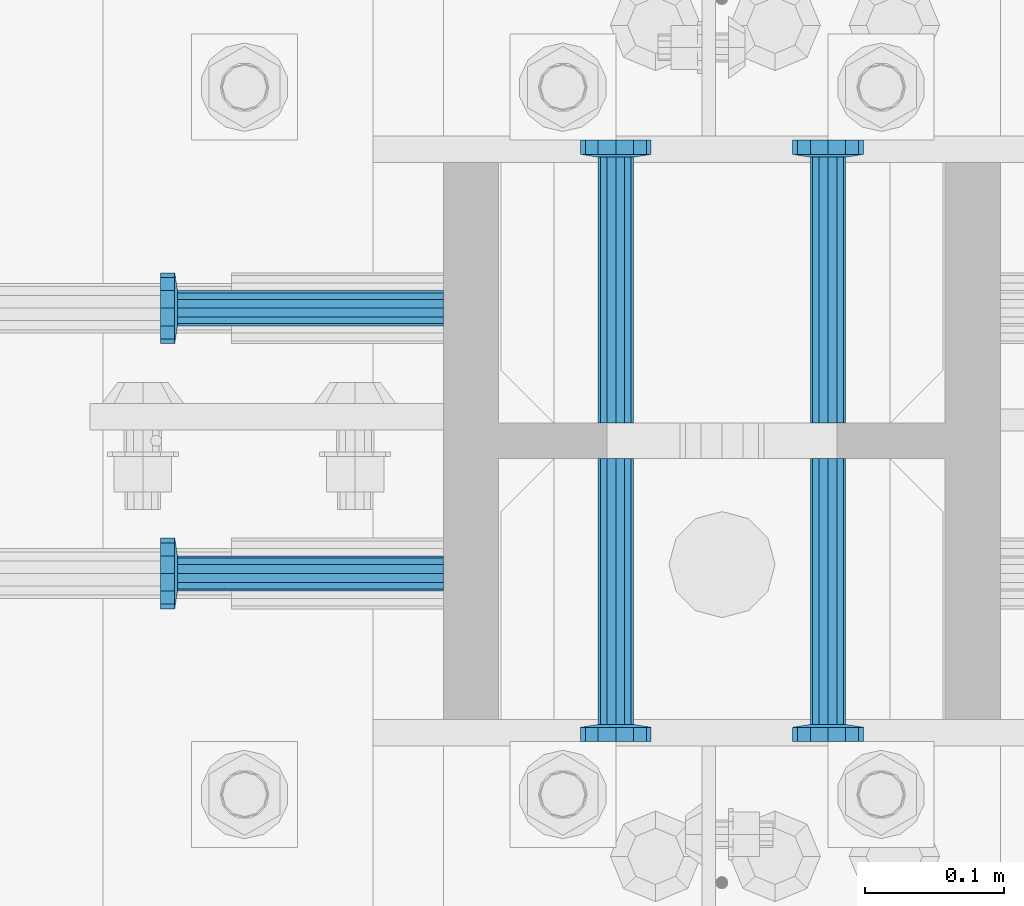
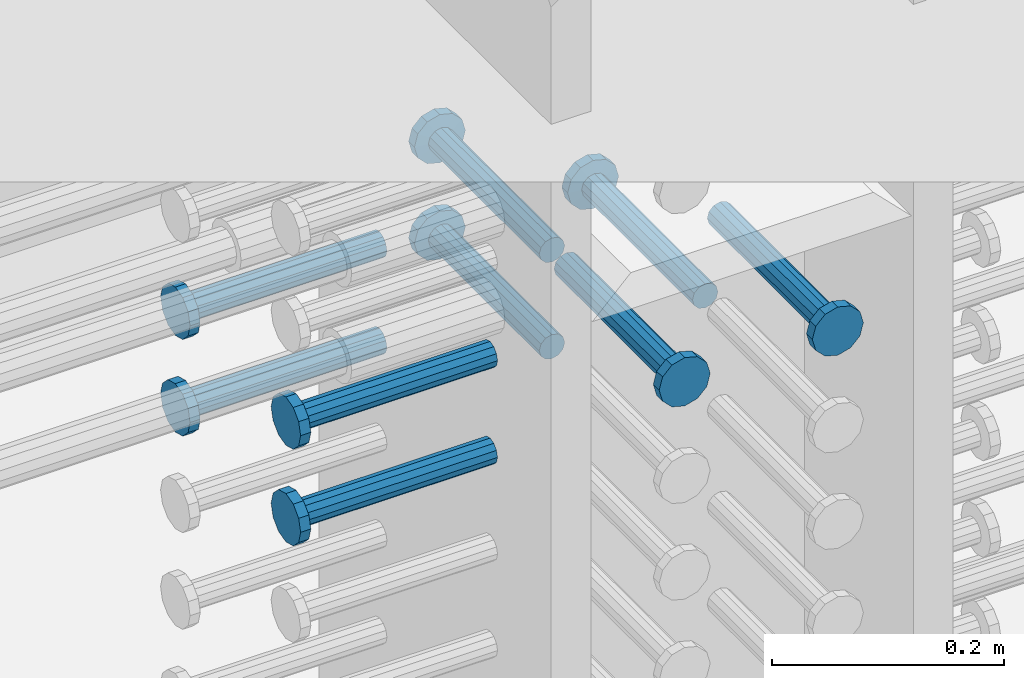
# One storey, part 1190 of 1763: 9 beams, 1 element without a shape of its own.
"""IFC2X3 building model written with IfcOpenShell, lengths in millimetres."""

from ifc_helpers import new_model, si_unit, frame, origin_with_axes, place, context, subcontext, project, spatial, faceted_brep, material, type_object, element, aggregate, save


model = new_model("IFC2X3")

# Units and contexts
model_context = context("Model", 3, precision=1e-05, world=origin_with_axes())
body_context = subcontext(model_context, "Body", "Model", "MODEL_VIEW")
ifc_project = project(units=[si_unit("LENGTHUNIT", "METRE", prefix="MILLI"), si_unit("AREAUNIT", "SQUARE_METRE"), si_unit("VOLUMEUNIT", "CUBIC_METRE"), si_unit("MASSUNIT", "GRAM", prefix="KILO"), si_unit("TIMEUNIT", "SECOND"), si_unit("PLANEANGLEUNIT", "RADIAN"), si_unit("SOLIDANGLEUNIT", "STERADIAN"), si_unit("THERMODYNAMICTEMPERATUREUNIT", "DEGREE_CELSIUS"), si_unit("LUMINOUSINTENSITYUNIT", "LUMEN")], contexts=[model_context])

# Site, building, storey
site_placement = place(None, origin_with_axes())
site = spatial("IfcSite", under=ifc_project, at=site_placement, CompositionType="ELEMENT")
building_placement = place(site_placement, origin_with_axes())
building = spatial("IfcBuilding", under=site, at=building_placement, Name="Undefined", CompositionType="ELEMENT")
storey_placement = place(building_placement, origin_with_axes())
storey = spatial("IfcBuildingStorey", under=building, at=storey_placement, Name="Undefined", CompositionType="ELEMENT", Elevation=0.0)

# Assembly, beams
assembly_placement = place(storey_placement, origin_with_axes())
assembly = element("IfcElementAssembly", 1, at=assembly_placement, inside=storey, Name="COLUMN", AssemblyPlace="NOTDEFINED", PredefinedType="RIGID_FRAME")
ifc_material = material(Name="STEEL/A108")
beam_type = type_object("IfcBeamType", PredefinedType="NOTDEFINED")
beam_1_placement = place(assembly_placement, frame((-72567.2373430988, 469.899999003702, 4724.40000000007), z_axis=(1.0, 0.0, 0.0), x_axis=(0.0, 1.0, 0.0)))
beam_1 = element("IfcBeam", 2, at=beam_1_placement, type_object=beam_type, material=ifc_material, Name="HEADED STUD ANCHOR", context=body_context, shape_type="Brep", body=[
    faceted_brep([(0.0, -12.6999999999971, -1.81898940354586e-12), (3.63797880709171e-12, -11.0, -6.34999990463257), (191.00799999576, -11.0, -6.34999990454889), (191.007999995752, -12.6999998092651, 8.36735125631094e-11), (7.27595761418343e-12, -6.34999990463257, -11.0), (191.00799999576, -6.34999990463257, -10.9999999999163), (3.63797880709171e-12, 0.0, -12.6999998092651), (191.00799999576, 0.0, -12.6999998091815), (7.27595761418343e-12, 6.34999990463257, -11.0), (191.00799999576, 6.34999990463257, -10.9999999999163), (3.63797880709171e-12, 11.0, -6.34999990463257), (191.00799999576, 11.0, -6.34999990454889), (0.0, 12.6999999999971, -1.81898940354586e-12), (191.007999995752, 12.6999998092651, 8.36735125631094e-11), (0.0, 11.0, 6.34999990463257), (191.007999995752, 11.0, 6.34999990471624), (-3.63797880709171e-12, 6.34999990463257, 11.0), (191.007999995749, 6.34999990463257, 11.0000000000837), (-3.63797880709171e-12, 0.0, 12.6999998092651), (191.007999995749, 0.0, 12.6999998093488), (-3.63797880709171e-12, -6.34999990463257, 11.0), (191.007999995749, -6.34999990463257, 11.0000000000837), (0.0, -11.0, 6.34999990463257), (191.007999995752, -11.0, 6.34999990471624), (193.039999995715, -22.0, -12.6999998091796), (193.039999995708, -25.3999996185303, 8.54925019666553e-11), (193.039999995719, -12.6999998092651, -21.9999999999145), (193.039999995719, 0.0, -25.3999996184448), (193.039999995719, 12.6999998092651, -21.9999999999145), (193.039999995715, 22.0, -12.6999998091796), (193.039999995708, 25.3999996185303, 8.54925019666553e-11), (193.039999995704, 22.0, 12.6999998093506), (193.039999995701, 12.6999998092651, 22.0000000000855), (193.039999995697, 0.0, 25.3999996186158), (193.039999995701, -12.6999998092651, 22.0000000000855), (193.039999995704, -22.0, 12.6999998093506), (203.199999995486, -22.0, -12.6999998091742), (203.199999995482, -25.3999996185303, 9.09494701772928e-11), (203.199999995493, -12.6999998092651, -21.9999999999091), (203.199999995493, 0.0, -25.3999996184393), (203.199999995493, 12.6999998092651, -21.9999999999091), (203.199999995486, 22.0, -12.6999998091742), (203.199999995482, 25.3999996185303, 9.09494701772928e-11), (203.199999995479, 22.0, 12.6999998093561), (203.199999995475, 12.6999998092651, 22.0000000000909), (203.199999995471, 0.0, 25.3999996186212), (203.199999995475, -12.6999998092651, 22.0000000000909), (203.199999995479, -22.0, 12.6999998093561)], [[[0, 1, 2, 3]], [[1, 4, 5, 2]], [[4, 6, 7, 5]], [[6, 8, 9, 7]], [[8, 10, 11, 9]], [[10, 12, 13, 11]], [[12, 14, 15, 13]], [[14, 16, 17, 15]], [[16, 18, 19, 17]], [[18, 20, 21, 19]], [[20, 22, 23, 21]], [[22, 0, 3, 23]], [[22, 20, 18, 16, 14, 12, 10, 8, 6, 4, 1, 0]], [[3, 2, 24, 25]], [[2, 5, 26, 24]], [[5, 7, 27, 26]], [[7, 9, 28, 27]], [[9, 11, 29, 28]], [[11, 13, 30, 29]], [[13, 15, 31, 30]], [[15, 17, 32, 31]], [[17, 19, 33, 32]], [[19, 21, 34, 33]], [[21, 23, 35, 34]], [[23, 3, 25, 35]], [[25, 24, 36, 37]], [[24, 26, 38, 36]], [[26, 27, 39, 38]], [[27, 28, 40, 39]], [[28, 29, 41, 40]], [[29, 30, 42, 41]], [[30, 31, 43, 42]], [[31, 32, 44, 43]], [[32, 33, 45, 44]], [[33, 34, 46, 45]], [[34, 35, 47, 46]], [[35, 25, 37, 47]], [[38, 39, 40, 41, 42, 43, 44, 45, 46, 47, 37, 36]]]),
])
beam_2_placement = place(assembly_placement, frame((-72691.0622049617, 552.45000000066, 4724.40000000007), z_axis=(0.0, 1.0, 0.0), x_axis=(-1.0, 0.0, 0.0)))
beam_2 = element("IfcBeam", 3, at=beam_2_placement, type_object=beam_type, material=ifc_material, Name="HEADED STUD ANCHOR", context=body_context, shape_type="Brep", body=[
    faceted_brep([(0.0, -12.6999999999971, -1.81898940354586e-12), (3.63797880709171e-12, -11.0, -6.34999990463257), (191.00799999576, -11.0, -6.34999990454889), (191.007999995752, -12.6999998092651, 8.36735125631094e-11), (7.27595761418343e-12, -6.34999990463257, -11.0), (191.00799999576, -6.34999990463257, -10.9999999999163), (3.63797880709171e-12, 0.0, -12.6999998092651), (191.00799999576, 0.0, -12.6999998091815), (7.27595761418343e-12, 6.34999990463257, -11.0), (191.00799999576, 6.34999990463257, -10.9999999999163), (3.63797880709171e-12, 11.0, -6.34999990463257), (191.00799999576, 11.0, -6.34999990454889), (0.0, 12.6999999999971, -1.81898940354586e-12), (191.007999995752, 12.6999998092651, 8.36735125631094e-11), (0.0, 11.0, 6.34999990463257), (191.007999995752, 11.0, 6.34999990471624), (-3.63797880709171e-12, 6.34999990463257, 11.0), (191.007999995749, 6.34999990463257, 11.0000000000837), (-3.63797880709171e-12, 0.0, 12.6999998092651), (191.007999995749, 0.0, 12.6999998093488), (-3.63797880709171e-12, -6.34999990463257, 11.0), (191.007999995749, -6.34999990463257, 11.0000000000837), (0.0, -11.0, 6.34999990463257), (191.007999995752, -11.0, 6.34999990471624), (193.039999995715, -22.0, -12.6999998091796), (193.039999995708, -25.3999996185303, 8.54925019666553e-11), (193.039999995719, -12.6999998092651, -21.9999999999145), (193.039999995719, 0.0, -25.3999996184448), (193.039999995719, 12.6999998092651, -21.9999999999145), (193.039999995715, 22.0, -12.6999998091796), (193.039999995708, 25.3999996185303, 8.54925019666553e-11), (193.039999995704, 22.0, 12.6999998093506), (193.039999995701, 12.6999998092651, 22.0000000000855), (193.039999995697, 0.0, 25.3999996186158), (193.039999995701, -12.6999998092651, 22.0000000000855), (193.039999995704, -22.0, 12.6999998093506), (203.199999995486, -22.0, -12.6999998091742), (203.199999995482, -25.3999996185303, 9.09494701772928e-11), (203.199999995493, -12.6999998092651, -21.9999999999091), (203.199999995493, 0.0, -25.3999996184393), (203.199999995493, 12.6999998092651, -21.9999999999091), (203.199999995486, 22.0, -12.6999998091742), (203.199999995482, 25.3999996185303, 9.09494701772928e-11), (203.199999995479, 22.0, 12.6999998093561), (203.199999995475, 12.6999998092651, 22.0000000000909), (203.199999995471, 0.0, 25.3999996186212), (203.199999995475, -12.6999998092651, 22.0000000000909), (203.199999995479, -22.0, 12.6999998093561)], [[[0, 1, 2, 3]], [[1, 4, 5, 2]], [[4, 6, 7, 5]], [[6, 8, 9, 7]], [[8, 10, 11, 9]], [[10, 12, 13, 11]], [[12, 14, 15, 13]], [[14, 16, 17, 15]], [[16, 18, 19, 17]], [[18, 20, 21, 19]], [[20, 22, 23, 21]], [[22, 0, 3, 23]], [[22, 20, 18, 16, 14, 12, 10, 8, 6, 4, 1, 0]], [[3, 2, 24, 25]], [[2, 5, 26, 24]], [[5, 7, 27, 26]], [[7, 9, 28, 27]], [[9, 11, 29, 28]], [[11, 13, 30, 29]], [[13, 15, 31, 30]], [[15, 17, 32, 31]], [[17, 19, 33, 32]], [[19, 21, 34, 33]], [[21, 23, 35, 34]], [[23, 3, 25, 35]], [[25, 24, 36, 37]], [[24, 26, 38, 36]], [[26, 27, 39, 38]], [[27, 28, 40, 39]], [[28, 29, 41, 40]], [[29, 30, 42, 41]], [[30, 31, 43, 42]], [[31, 32, 44, 43]], [[32, 33, 45, 44]], [[33, 34, 46, 45]], [[34, 35, 47, 46]], [[35, 25, 37, 47]], [[38, 39, 40, 41, 42, 43, 44, 45, 46, 47, 37, 36]]]),
])
beam_3_placement = place(assembly_placement, frame((-72691.0622736973, 361.950000000834, 4724.40000000007), z_axis=(0.0, 1.0, 0.0), x_axis=(-1.0, 0.0, 0.0)))
beam_3 = element("IfcBeam", 4, at=beam_3_placement, type_object=beam_type, material=ifc_material, Name="HEADED STUD ANCHOR", context=body_context, shape_type="Brep", body=[
    faceted_brep([(0.0, -12.6999999999971, -1.81898940354586e-12), (3.63797880709171e-12, -11.0, -6.34999990463257), (191.00799999576, -11.0, -6.34999990454889), (191.007999995752, -12.6999998092651, 8.36735125631094e-11), (7.27595761418343e-12, -6.34999990463257, -11.0), (191.00799999576, -6.34999990463257, -10.9999999999163), (3.63797880709171e-12, 0.0, -12.6999998092651), (191.00799999576, 0.0, -12.6999998091815), (7.27595761418343e-12, 6.34999990463257, -11.0), (191.00799999576, 6.34999990463257, -10.9999999999163), (3.63797880709171e-12, 11.0, -6.34999990463257), (191.00799999576, 11.0, -6.34999990454889), (0.0, 12.6999999999971, -1.81898940354586e-12), (191.007999995752, 12.6999998092651, 8.36735125631094e-11), (0.0, 11.0, 6.34999990463257), (191.007999995752, 11.0, 6.34999990471624), (-3.63797880709171e-12, 6.34999990463257, 11.0), (191.007999995749, 6.34999990463257, 11.0000000000837), (-3.63797880709171e-12, 0.0, 12.6999998092651), (191.007999995749, 0.0, 12.6999998093488), (-3.63797880709171e-12, -6.34999990463257, 11.0), (191.007999995749, -6.34999990463257, 11.0000000000837), (0.0, -11.0, 6.34999990463257), (191.007999995752, -11.0, 6.34999990471624), (193.039999995715, -22.0, -12.6999998091796), (193.039999995708, -25.3999996185303, 8.54925019666553e-11), (193.039999995719, -12.6999998092651, -21.9999999999145), (193.039999995719, 0.0, -25.3999996184448), (193.039999995719, 12.6999998092651, -21.9999999999145), (193.039999995715, 22.0, -12.6999998091796), (193.039999995708, 25.3999996185303, 8.54925019666553e-11), (193.039999995704, 22.0, 12.6999998093506), (193.039999995701, 12.6999998092651, 22.0000000000855), (193.039999995697, 0.0, 25.3999996186158), (193.039999995701, -12.6999998092651, 22.0000000000855), (193.039999995704, -22.0, 12.6999998093506), (203.199999995486, -22.0, -12.6999998091742), (203.199999995482, -25.3999996185303, 9.09494701772928e-11), (203.199999995493, -12.6999998092651, -21.9999999999091), (203.199999995493, 0.0, -25.3999996184393), (203.199999995493, 12.6999998092651, -21.9999999999091), (203.199999995486, 22.0, -12.6999998091742), (203.199999995482, 25.3999996185303, 9.09494701772928e-11), (203.199999995479, 22.0, 12.6999998093561), (203.199999995475, 12.6999998092651, 22.0000000000909), (203.199999995471, 0.0, 25.3999996186212), (203.199999995475, -12.6999998092651, 22.0000000000909), (203.199999995479, -22.0, 12.6999998093561)], [[[0, 1, 2, 3]], [[1, 4, 5, 2]], [[4, 6, 7, 5]], [[6, 8, 9, 7]], [[8, 10, 11, 9]], [[10, 12, 13, 11]], [[12, 14, 15, 13]], [[14, 16, 17, 15]], [[16, 18, 19, 17]], [[18, 20, 21, 19]], [[20, 22, 23, 21]], [[22, 0, 3, 23]], [[22, 20, 18, 16, 14, 12, 10, 8, 6, 4, 1, 0]], [[3, 2, 24, 25]], [[2, 5, 26, 24]], [[5, 7, 27, 26]], [[7, 9, 28, 27]], [[9, 11, 29, 28]], [[11, 13, 30, 29]], [[13, 15, 31, 30]], [[15, 17, 32, 31]], [[17, 19, 33, 32]], [[19, 21, 34, 33]], [[21, 23, 35, 34]], [[23, 3, 25, 35]], [[25, 24, 36, 37]], [[24, 26, 38, 36]], [[26, 27, 39, 38]], [[27, 28, 40, 39]], [[28, 29, 41, 40]], [[29, 30, 42, 41]], [[30, 31, 43, 42]], [[31, 32, 44, 43]], [[32, 33, 45, 44]], [[33, 34, 46, 45]], [[34, 35, 47, 46]], [[35, 25, 37, 47]], [[38, 39, 40, 41, 42, 43, 44, 45, 46, 47, 37, 36]]]),
])
beam_4_placement = place(assembly_placement, frame((-72567.2373420903, 444.499999886566, 4724.40000000007), z_axis=(1.0, 0.0, 0.0), x_axis=(0.0, -1.0, 0.0)))
beam_4 = element("IfcBeam", 5, at=beam_4_placement, type_object=beam_type, material=ifc_material, Name="HEADED STUD ANCHOR", context=body_context, shape_type="Brep", body=[
    faceted_brep([(0.0, -12.6999999999971, -1.81898940354586e-12), (3.63797880709171e-12, -11.0, -6.34999990463257), (191.00799999576, -11.0, -6.34999990454889), (191.007999995752, -12.6999998092651, 8.36735125631094e-11), (7.27595761418343e-12, -6.34999990463257, -11.0), (191.00799999576, -6.34999990463257, -10.9999999999163), (3.63797880709171e-12, 0.0, -12.6999998092651), (191.00799999576, 0.0, -12.6999998091815), (7.27595761418343e-12, 6.34999990463257, -11.0), (191.00799999576, 6.34999990463257, -10.9999999999163), (3.63797880709171e-12, 11.0, -6.34999990463257), (191.00799999576, 11.0, -6.34999990454889), (0.0, 12.6999999999971, -1.81898940354586e-12), (191.007999995752, 12.6999998092651, 8.36735125631094e-11), (0.0, 11.0, 6.34999990463257), (191.007999995752, 11.0, 6.34999990471624), (-3.63797880709171e-12, 6.34999990463257, 11.0), (191.007999995749, 6.34999990463257, 11.0000000000837), (-3.63797880709171e-12, 0.0, 12.6999998092651), (191.007999995749, 0.0, 12.6999998093488), (-3.63797880709171e-12, -6.34999990463257, 11.0), (191.007999995749, -6.34999990463257, 11.0000000000837), (0.0, -11.0, 6.34999990463257), (191.007999995752, -11.0, 6.34999990471624), (193.039999995715, -22.0, -12.6999998091796), (193.039999995708, -25.3999996185303, 8.54925019666553e-11), (193.039999995719, -12.6999998092651, -21.9999999999145), (193.039999995719, 0.0, -25.3999996184448), (193.039999995719, 12.6999998092651, -21.9999999999145), (193.039999995715, 22.0, -12.6999998091796), (193.039999995708, 25.3999996185303, 8.54925019666553e-11), (193.039999995704, 22.0, 12.6999998093506), (193.039999995701, 12.6999998092651, 22.0000000000855), (193.039999995697, 0.0, 25.3999996186158), (193.039999995701, -12.6999998092651, 22.0000000000855), (193.039999995704, -22.0, 12.6999998093506), (203.199999995486, -22.0, -12.6999998091742), (203.199999995482, -25.3999996185303, 9.09494701772928e-11), (203.199999995493, -12.6999998092651, -21.9999999999091), (203.199999995493, 0.0, -25.3999996184393), (203.199999995493, 12.6999998092651, -21.9999999999091), (203.199999995486, 22.0, -12.6999998091742), (203.199999995482, 25.3999996185303, 9.09494701772928e-11), (203.199999995479, 22.0, 12.6999998093561), (203.199999995475, 12.6999998092651, 22.0000000000909), (203.199999995471, 0.0, 25.3999996186212), (203.199999995475, -12.6999998092651, 22.0000000000909), (203.199999995479, -22.0, 12.6999998093561)], [[[0, 1, 2, 3]], [[1, 4, 5, 2]], [[4, 6, 7, 5]], [[6, 8, 9, 7]], [[8, 10, 11, 9]], [[10, 12, 13, 11]], [[12, 14, 15, 13]], [[14, 16, 17, 15]], [[16, 18, 19, 17]], [[18, 20, 21, 19]], [[20, 22, 23, 21]], [[22, 0, 3, 23]], [[22, 20, 18, 16, 14, 12, 10, 8, 6, 4, 1, 0]], [[3, 2, 24, 25]], [[2, 5, 26, 24]], [[5, 7, 27, 26]], [[7, 9, 28, 27]], [[9, 11, 29, 28]], [[11, 13, 30, 29]], [[13, 15, 31, 30]], [[15, 17, 32, 31]], [[17, 19, 33, 32]], [[19, 21, 34, 33]], [[21, 23, 35, 34]], [[23, 3, 25, 35]], [[25, 24, 36, 37]], [[24, 26, 38, 36]], [[26, 27, 39, 38]], [[27, 28, 40, 39]], [[28, 29, 41, 40]], [[29, 30, 42, 41]], [[30, 31, 43, 42]], [[31, 32, 44, 43]], [[32, 33, 45, 44]], [[33, 34, 46, 45]], [[34, 35, 47, 46]], [[35, 25, 37, 47]], [[38, 39, 40, 41, 42, 43, 44, 45, 46, 47, 37, 36]]]),
])
beam_5_placement = place(assembly_placement, frame((-72414.8373420912, 444.500000000843, 4724.40000000007), z_axis=(1.0, 0.0, 0.0), x_axis=(0.0, -1.0, 0.0)))
beam_5 = element("IfcBeam", 6, at=beam_5_placement, type_object=beam_type, material=ifc_material, Name="HEADED STUD ANCHOR", context=body_context, shape_type="Brep", body=[
    faceted_brep([(0.0, -12.6999999999971, -1.81898940354586e-12), (3.63797880709171e-12, -11.0, -6.34999990463257), (191.00799999576, -11.0, -6.34999990454889), (191.007999995752, -12.6999998092651, 8.36735125631094e-11), (7.27595761418343e-12, -6.34999990463257, -11.0), (191.00799999576, -6.34999990463257, -10.9999999999163), (3.63797880709171e-12, 0.0, -12.6999998092651), (191.00799999576, 0.0, -12.6999998091815), (7.27595761418343e-12, 6.34999990463257, -11.0), (191.00799999576, 6.34999990463257, -10.9999999999163), (3.63797880709171e-12, 11.0, -6.34999990463257), (191.00799999576, 11.0, -6.34999990454889), (0.0, 12.6999999999971, -1.81898940354586e-12), (191.007999995752, 12.6999998092651, 8.36735125631094e-11), (0.0, 11.0, 6.34999990463257), (191.007999995752, 11.0, 6.34999990471624), (-3.63797880709171e-12, 6.34999990463257, 11.0), (191.007999995749, 6.34999990463257, 11.0000000000837), (-3.63797880709171e-12, 0.0, 12.6999998092651), (191.007999995749, 0.0, 12.6999998093488), (-3.63797880709171e-12, -6.34999990463257, 11.0), (191.007999995749, -6.34999990463257, 11.0000000000837), (0.0, -11.0, 6.34999990463257), (191.007999995752, -11.0, 6.34999990471624), (193.039999995715, -22.0, -12.6999998091796), (193.039999995708, -25.3999996185303, 8.54925019666553e-11), (193.039999995719, -12.6999998092651, -21.9999999999145), (193.039999995719, 0.0, -25.3999996184448), (193.039999995719, 12.6999998092651, -21.9999999999145), (193.039999995715, 22.0, -12.6999998091796), (193.039999995708, 25.3999996185303, 8.54925019666553e-11), (193.039999995704, 22.0, 12.6999998093506), (193.039999995701, 12.6999998092651, 22.0000000000855), (193.039999995697, 0.0, 25.3999996186158), (193.039999995701, -12.6999998092651, 22.0000000000855), (193.039999995704, -22.0, 12.6999998093506), (203.199999995486, -22.0, -12.6999998091742), (203.199999995482, -25.3999996185303, 9.09494701772928e-11), (203.199999995493, -12.6999998092651, -21.9999999999091), (203.199999995493, 0.0, -25.3999996184393), (203.199999995493, 12.6999998092651, -21.9999999999091), (203.199999995486, 22.0, -12.6999998091742), (203.199999995482, 25.3999996185303, 9.09494701772928e-11), (203.199999995479, 22.0, 12.6999998093561), (203.199999995475, 12.6999998092651, 22.0000000000909), (203.199999995471, 0.0, 25.3999996186212), (203.199999995475, -12.6999998092651, 22.0000000000909), (203.199999995479, -22.0, 12.6999998093561)], [[[0, 1, 2, 3]], [[1, 4, 5, 2]], [[4, 6, 7, 5]], [[6, 8, 9, 7]], [[8, 10, 11, 9]], [[10, 12, 13, 11]], [[12, 14, 15, 13]], [[14, 16, 17, 15]], [[16, 18, 19, 17]], [[18, 20, 21, 19]], [[20, 22, 23, 21]], [[22, 0, 3, 23]], [[22, 20, 18, 16, 14, 12, 10, 8, 6, 4, 1, 0]], [[3, 2, 24, 25]], [[2, 5, 26, 24]], [[5, 7, 27, 26]], [[7, 9, 28, 27]], [[9, 11, 29, 28]], [[11, 13, 30, 29]], [[13, 15, 31, 30]], [[15, 17, 32, 31]], [[17, 19, 33, 32]], [[19, 21, 34, 33]], [[21, 23, 35, 34]], [[23, 3, 25, 35]], [[25, 24, 36, 37]], [[24, 26, 38, 36]], [[26, 27, 39, 38]], [[27, 28, 40, 39]], [[28, 29, 41, 40]], [[29, 30, 42, 41]], [[30, 31, 43, 42]], [[31, 32, 44, 43]], [[32, 33, 45, 44]], [[33, 34, 46, 45]], [[34, 35, 47, 46]], [[35, 25, 37, 47]], [[38, 39, 40, 41, 42, 43, 44, 45, 46, 47, 37, 36]]]),
])
beam_6_placement = place(assembly_placement, frame((-72414.837343099, 469.900000000843, 4622.80000000005), z_axis=(1.0, 0.0, 0.0), x_axis=(0.0, 1.0, 0.0)))
beam_6 = element("IfcBeam", 7, at=beam_6_placement, type_object=beam_type, material=ifc_material, Name="HEADED STUD ANCHOR", context=body_context, shape_type="Brep", body=[
    faceted_brep([(0.0, -12.6999999999971, -1.81898940354586e-12), (3.63797880709171e-12, -11.0, -6.34999990463257), (191.00799999576, -11.0, -6.34999990454889), (191.007999995752, -12.6999998092651, 8.36735125631094e-11), (7.27595761418343e-12, -6.34999990463257, -11.0), (191.00799999576, -6.34999990463257, -10.9999999999163), (3.63797880709171e-12, 0.0, -12.6999998092651), (191.00799999576, 0.0, -12.6999998091815), (7.27595761418343e-12, 6.34999990463257, -11.0), (191.00799999576, 6.34999990463257, -10.9999999999163), (3.63797880709171e-12, 11.0, -6.34999990463257), (191.00799999576, 11.0, -6.34999990454889), (0.0, 12.6999999999971, -1.81898940354586e-12), (191.007999995752, 12.6999998092651, 8.36735125631094e-11), (0.0, 11.0, 6.34999990463257), (191.007999995752, 11.0, 6.34999990471624), (-3.63797880709171e-12, 6.34999990463257, 11.0), (191.007999995749, 6.34999990463257, 11.0000000000837), (-3.63797880709171e-12, 0.0, 12.6999998092651), (191.007999995749, 0.0, 12.6999998093488), (-3.63797880709171e-12, -6.34999990463257, 11.0), (191.007999995749, -6.34999990463257, 11.0000000000837), (0.0, -11.0, 6.34999990463257), (191.007999995752, -11.0, 6.34999990471624), (193.039999995715, -22.0, -12.6999998091796), (193.039999995708, -25.3999996185303, 8.54925019666553e-11), (193.039999995719, -12.6999998092651, -21.9999999999145), (193.039999995719, 0.0, -25.3999996184448), (193.039999995719, 12.6999998092651, -21.9999999999145), (193.039999995715, 22.0, -12.6999998091796), (193.039999995708, 25.3999996185303, 8.54925019666553e-11), (193.039999995704, 22.0, 12.6999998093506), (193.039999995701, 12.6999998092651, 22.0000000000855), (193.039999995697, 0.0, 25.3999996186158), (193.039999995701, -12.6999998092651, 22.0000000000855), (193.039999995704, -22.0, 12.6999998093506), (203.199999995486, -22.0, -12.6999998091742), (203.199999995482, -25.3999996185303, 9.09494701772928e-11), (203.199999995493, -12.6999998092651, -21.9999999999091), (203.199999995493, 0.0, -25.3999996184393), (203.199999995493, 12.6999998092651, -21.9999999999091), (203.199999995486, 22.0, -12.6999998091742), (203.199999995482, 25.3999996185303, 9.09494701772928e-11), (203.199999995479, 22.0, 12.6999998093561), (203.199999995475, 12.6999998092651, 22.0000000000909), (203.199999995471, 0.0, 25.3999996186212), (203.199999995475, -12.6999998092651, 22.0000000000909), (203.199999995479, -22.0, 12.6999998093561)], [[[0, 1, 2, 3]], [[1, 4, 5, 2]], [[4, 6, 7, 5]], [[6, 8, 9, 7]], [[8, 10, 11, 9]], [[10, 12, 13, 11]], [[12, 14, 15, 13]], [[14, 16, 17, 15]], [[16, 18, 19, 17]], [[18, 20, 21, 19]], [[20, 22, 23, 21]], [[22, 0, 3, 23]], [[22, 20, 18, 16, 14, 12, 10, 8, 6, 4, 1, 0]], [[3, 2, 24, 25]], [[2, 5, 26, 24]], [[5, 7, 27, 26]], [[7, 9, 28, 27]], [[9, 11, 29, 28]], [[11, 13, 30, 29]], [[13, 15, 31, 30]], [[15, 17, 32, 31]], [[17, 19, 33, 32]], [[19, 21, 34, 33]], [[21, 23, 35, 34]], [[23, 3, 25, 35]], [[25, 24, 36, 37]], [[24, 26, 38, 36]], [[26, 27, 39, 38]], [[27, 28, 40, 39]], [[28, 29, 41, 40]], [[29, 30, 42, 41]], [[30, 31, 43, 42]], [[31, 32, 44, 43]], [[32, 33, 45, 44]], [[33, 34, 46, 45]], [[34, 35, 47, 46]], [[35, 25, 37, 47]], [[38, 39, 40, 41, 42, 43, 44, 45, 46, 47, 37, 36]]]),
])
beam_7_placement = place(assembly_placement, frame((-72567.2373430988, 469.899999003702, 4622.80000000005), z_axis=(1.0, 0.0, 0.0), x_axis=(0.0, 1.0, 0.0)))
beam_7 = element("IfcBeam", 8, at=beam_7_placement, type_object=beam_type, material=ifc_material, Name="HEADED STUD ANCHOR", context=body_context, shape_type="Brep", body=[
    faceted_brep([(0.0, -12.6999999999971, -1.81898940354586e-12), (3.63797880709171e-12, -11.0, -6.34999990463257), (191.00799999576, -11.0, -6.34999990454889), (191.007999995752, -12.6999998092651, 8.36735125631094e-11), (7.27595761418343e-12, -6.34999990463257, -11.0), (191.00799999576, -6.34999990463257, -10.9999999999163), (3.63797880709171e-12, 0.0, -12.6999998092651), (191.00799999576, 0.0, -12.6999998091815), (7.27595761418343e-12, 6.34999990463257, -11.0), (191.00799999576, 6.34999990463257, -10.9999999999163), (3.63797880709171e-12, 11.0, -6.34999990463257), (191.00799999576, 11.0, -6.34999990454889), (0.0, 12.6999999999971, -1.81898940354586e-12), (191.007999995752, 12.6999998092651, 8.36735125631094e-11), (0.0, 11.0, 6.34999990463257), (191.007999995752, 11.0, 6.34999990471624), (-3.63797880709171e-12, 6.34999990463257, 11.0), (191.007999995749, 6.34999990463257, 11.0000000000837), (-3.63797880709171e-12, 0.0, 12.6999998092651), (191.007999995749, 0.0, 12.6999998093488), (-3.63797880709171e-12, -6.34999990463257, 11.0), (191.007999995749, -6.34999990463257, 11.0000000000837), (0.0, -11.0, 6.34999990463257), (191.007999995752, -11.0, 6.34999990471624), (193.039999995715, -22.0, -12.6999998091796), (193.039999995708, -25.3999996185303, 8.54925019666553e-11), (193.039999995719, -12.6999998092651, -21.9999999999145), (193.039999995719, 0.0, -25.3999996184448), (193.039999995719, 12.6999998092651, -21.9999999999145), (193.039999995715, 22.0, -12.6999998091796), (193.039999995708, 25.3999996185303, 8.54925019666553e-11), (193.039999995704, 22.0, 12.6999998093506), (193.039999995701, 12.6999998092651, 22.0000000000855), (193.039999995697, 0.0, 25.3999996186158), (193.039999995701, -12.6999998092651, 22.0000000000855), (193.039999995704, -22.0, 12.6999998093506), (203.199999995486, -22.0, -12.6999998091742), (203.199999995482, -25.3999996185303, 9.09494701772928e-11), (203.199999995493, -12.6999998092651, -21.9999999999091), (203.199999995493, 0.0, -25.3999996184393), (203.199999995493, 12.6999998092651, -21.9999999999091), (203.199999995486, 22.0, -12.6999998091742), (203.199999995482, 25.3999996185303, 9.09494701772928e-11), (203.199999995479, 22.0, 12.6999998093561), (203.199999995475, 12.6999998092651, 22.0000000000909), (203.199999995471, 0.0, 25.3999996186212), (203.199999995475, -12.6999998092651, 22.0000000000909), (203.199999995479, -22.0, 12.6999998093561)], [[[0, 1, 2, 3]], [[1, 4, 5, 2]], [[4, 6, 7, 5]], [[6, 8, 9, 7]], [[8, 10, 11, 9]], [[10, 12, 13, 11]], [[12, 14, 15, 13]], [[14, 16, 17, 15]], [[16, 18, 19, 17]], [[18, 20, 21, 19]], [[20, 22, 23, 21]], [[22, 0, 3, 23]], [[22, 20, 18, 16, 14, 12, 10, 8, 6, 4, 1, 0]], [[3, 2, 24, 25]], [[2, 5, 26, 24]], [[5, 7, 27, 26]], [[7, 9, 28, 27]], [[9, 11, 29, 28]], [[11, 13, 30, 29]], [[13, 15, 31, 30]], [[15, 17, 32, 31]], [[17, 19, 33, 32]], [[19, 21, 34, 33]], [[21, 23, 35, 34]], [[23, 3, 25, 35]], [[25, 24, 36, 37]], [[24, 26, 38, 36]], [[26, 27, 39, 38]], [[27, 28, 40, 39]], [[28, 29, 41, 40]], [[29, 30, 42, 41]], [[30, 31, 43, 42]], [[31, 32, 44, 43]], [[32, 33, 45, 44]], [[33, 34, 46, 45]], [[34, 35, 47, 46]], [[35, 25, 37, 47]], [[38, 39, 40, 41, 42, 43, 44, 45, 46, 47, 37, 36]]]),
])
beam_8_placement = place(assembly_placement, frame((-72691.0622049617, 552.45000000066, 4622.80000000005), z_axis=(0.0, 1.0, 0.0), x_axis=(-1.0, 0.0, 0.0)))
beam_8 = element("IfcBeam", 9, at=beam_8_placement, type_object=beam_type, material=ifc_material, Name="HEADED STUD ANCHOR", context=body_context, shape_type="Brep", body=[
    faceted_brep([(0.0, -12.6999999999971, -1.81898940354586e-12), (3.63797880709171e-12, -11.0, -6.34999990463257), (191.00799999576, -11.0, -6.34999990454889), (191.007999995752, -12.6999998092651, 8.36735125631094e-11), (7.27595761418343e-12, -6.34999990463257, -11.0), (191.00799999576, -6.34999990463257, -10.9999999999163), (3.63797880709171e-12, 0.0, -12.6999998092651), (191.00799999576, 0.0, -12.6999998091815), (7.27595761418343e-12, 6.34999990463257, -11.0), (191.00799999576, 6.34999990463257, -10.9999999999163), (3.63797880709171e-12, 11.0, -6.34999990463257), (191.00799999576, 11.0, -6.34999990454889), (0.0, 12.6999999999971, -1.81898940354586e-12), (191.007999995752, 12.6999998092651, 8.36735125631094e-11), (0.0, 11.0, 6.34999990463257), (191.007999995752, 11.0, 6.34999990471624), (-3.63797880709171e-12, 6.34999990463257, 11.0), (191.007999995749, 6.34999990463257, 11.0000000000837), (-3.63797880709171e-12, 0.0, 12.6999998092651), (191.007999995749, 0.0, 12.6999998093488), (-3.63797880709171e-12, -6.34999990463257, 11.0), (191.007999995749, -6.34999990463257, 11.0000000000837), (0.0, -11.0, 6.34999990463257), (191.007999995752, -11.0, 6.34999990471624), (193.039999995715, -22.0, -12.6999998091796), (193.039999995708, -25.3999996185303, 8.54925019666553e-11), (193.039999995719, -12.6999998092651, -21.9999999999145), (193.039999995719, 0.0, -25.3999996184448), (193.039999995719, 12.6999998092651, -21.9999999999145), (193.039999995715, 22.0, -12.6999998091796), (193.039999995708, 25.3999996185303, 8.54925019666553e-11), (193.039999995704, 22.0, 12.6999998093506), (193.039999995701, 12.6999998092651, 22.0000000000855), (193.039999995697, 0.0, 25.3999996186158), (193.039999995701, -12.6999998092651, 22.0000000000855), (193.039999995704, -22.0, 12.6999998093506), (203.199999995486, -22.0, -12.6999998091742), (203.199999995482, -25.3999996185303, 9.09494701772928e-11), (203.199999995493, -12.6999998092651, -21.9999999999091), (203.199999995493, 0.0, -25.3999996184393), (203.199999995493, 12.6999998092651, -21.9999999999091), (203.199999995486, 22.0, -12.6999998091742), (203.199999995482, 25.3999996185303, 9.09494701772928e-11), (203.199999995479, 22.0, 12.6999998093561), (203.199999995475, 12.6999998092651, 22.0000000000909), (203.199999995471, 0.0, 25.3999996186212), (203.199999995475, -12.6999998092651, 22.0000000000909), (203.199999995479, -22.0, 12.6999998093561)], [[[0, 1, 2, 3]], [[1, 4, 5, 2]], [[4, 6, 7, 5]], [[6, 8, 9, 7]], [[8, 10, 11, 9]], [[10, 12, 13, 11]], [[12, 14, 15, 13]], [[14, 16, 17, 15]], [[16, 18, 19, 17]], [[18, 20, 21, 19]], [[20, 22, 23, 21]], [[22, 0, 3, 23]], [[22, 20, 18, 16, 14, 12, 10, 8, 6, 4, 1, 0]], [[3, 2, 24, 25]], [[2, 5, 26, 24]], [[5, 7, 27, 26]], [[7, 9, 28, 27]], [[9, 11, 29, 28]], [[11, 13, 30, 29]], [[13, 15, 31, 30]], [[15, 17, 32, 31]], [[17, 19, 33, 32]], [[19, 21, 34, 33]], [[21, 23, 35, 34]], [[23, 3, 25, 35]], [[25, 24, 36, 37]], [[24, 26, 38, 36]], [[26, 27, 39, 38]], [[27, 28, 40, 39]], [[28, 29, 41, 40]], [[29, 30, 42, 41]], [[30, 31, 43, 42]], [[31, 32, 44, 43]], [[32, 33, 45, 44]], [[33, 34, 46, 45]], [[34, 35, 47, 46]], [[35, 25, 37, 47]], [[38, 39, 40, 41, 42, 43, 44, 45, 46, 47, 37, 36]]]),
])
beam_9_placement = place(assembly_placement, frame((-72691.0622736973, 361.950000000834, 4622.80000000005), z_axis=(0.0, 1.0, 0.0), x_axis=(-1.0, 0.0, 0.0)))
beam_9 = element("IfcBeam", 10, at=beam_9_placement, type_object=beam_type, material=ifc_material, Name="HEADED STUD ANCHOR", context=body_context, shape_type="Brep", body=[
    faceted_brep([(0.0, -12.6999999999971, -1.81898940354586e-12), (3.63797880709171e-12, -11.0, -6.34999990463257), (191.00799999576, -11.0, -6.34999990454889), (191.007999995752, -12.6999998092651, 8.36735125631094e-11), (7.27595761418343e-12, -6.34999990463257, -11.0), (191.00799999576, -6.34999990463257, -10.9999999999163), (3.63797880709171e-12, 0.0, -12.6999998092651), (191.00799999576, 0.0, -12.6999998091815), (7.27595761418343e-12, 6.34999990463257, -11.0), (191.00799999576, 6.34999990463257, -10.9999999999163), (3.63797880709171e-12, 11.0, -6.34999990463257), (191.00799999576, 11.0, -6.34999990454889), (0.0, 12.6999999999971, -1.81898940354586e-12), (191.007999995752, 12.6999998092651, 8.36735125631094e-11), (0.0, 11.0, 6.34999990463257), (191.007999995752, 11.0, 6.34999990471624), (-3.63797880709171e-12, 6.34999990463257, 11.0), (191.007999995749, 6.34999990463257, 11.0000000000837), (-3.63797880709171e-12, 0.0, 12.6999998092651), (191.007999995749, 0.0, 12.6999998093488), (-3.63797880709171e-12, -6.34999990463257, 11.0), (191.007999995749, -6.34999990463257, 11.0000000000837), (0.0, -11.0, 6.34999990463257), (191.007999995752, -11.0, 6.34999990471624), (193.039999995715, -22.0, -12.6999998091796), (193.039999995708, -25.3999996185303, 8.54925019666553e-11), (193.039999995719, -12.6999998092651, -21.9999999999145), (193.039999995719, 0.0, -25.3999996184448), (193.039999995719, 12.6999998092651, -21.9999999999145), (193.039999995715, 22.0, -12.6999998091796), (193.039999995708, 25.3999996185303, 8.54925019666553e-11), (193.039999995704, 22.0, 12.6999998093506), (193.039999995701, 12.6999998092651, 22.0000000000855), (193.039999995697, 0.0, 25.3999996186158), (193.039999995701, -12.6999998092651, 22.0000000000855), (193.039999995704, -22.0, 12.6999998093506), (203.199999995486, -22.0, -12.6999998091742), (203.199999995482, -25.3999996185303, 9.09494701772928e-11), (203.199999995493, -12.6999998092651, -21.9999999999091), (203.199999995493, 0.0, -25.3999996184393), (203.199999995493, 12.6999998092651, -21.9999999999091), (203.199999995486, 22.0, -12.6999998091742), (203.199999995482, 25.3999996185303, 9.09494701772928e-11), (203.199999995479, 22.0, 12.6999998093561), (203.199999995475, 12.6999998092651, 22.0000000000909), (203.199999995471, 0.0, 25.3999996186212), (203.199999995475, -12.6999998092651, 22.0000000000909), (203.199999995479, -22.0, 12.6999998093561)], [[[0, 1, 2, 3]], [[1, 4, 5, 2]], [[4, 6, 7, 5]], [[6, 8, 9, 7]], [[8, 10, 11, 9]], [[10, 12, 13, 11]], [[12, 14, 15, 13]], [[14, 16, 17, 15]], [[16, 18, 19, 17]], [[18, 20, 21, 19]], [[20, 22, 23, 21]], [[22, 0, 3, 23]], [[22, 20, 18, 16, 14, 12, 10, 8, 6, 4, 1, 0]], [[3, 2, 24, 25]], [[2, 5, 26, 24]], [[5, 7, 27, 26]], [[7, 9, 28, 27]], [[9, 11, 29, 28]], [[11, 13, 30, 29]], [[13, 15, 31, 30]], [[15, 17, 32, 31]], [[17, 19, 33, 32]], [[19, 21, 34, 33]], [[21, 23, 35, 34]], [[23, 3, 25, 35]], [[25, 24, 36, 37]], [[24, 26, 38, 36]], [[26, 27, 39, 38]], [[27, 28, 40, 39]], [[28, 29, 41, 40]], [[29, 30, 42, 41]], [[30, 31, 43, 42]], [[31, 32, 44, 43]], [[32, 33, 45, 44]], [[33, 34, 46, 45]], [[34, 35, 47, 46]], [[35, 25, 37, 47]], [[38, 39, 40, 41, 42, 43, 44, 45, 46, 47, 37, 36]]]),
])
aggregate(assembly, [beam_1, beam_2, beam_3, beam_4, beam_5, beam_6, beam_7, beam_8, beam_9])

save(model, "model.ifc")
